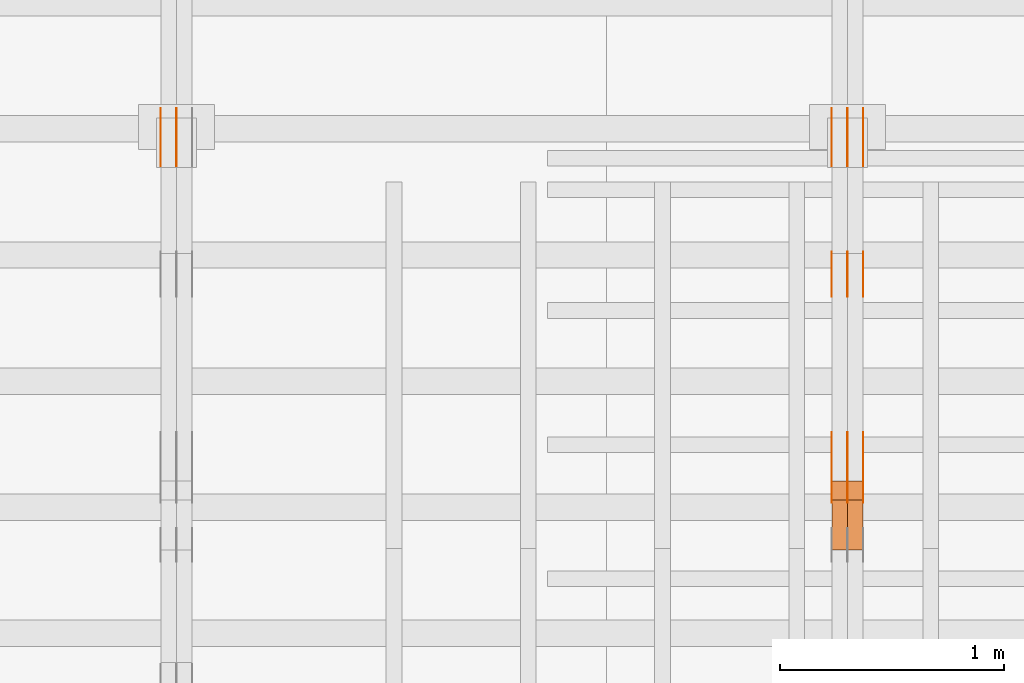
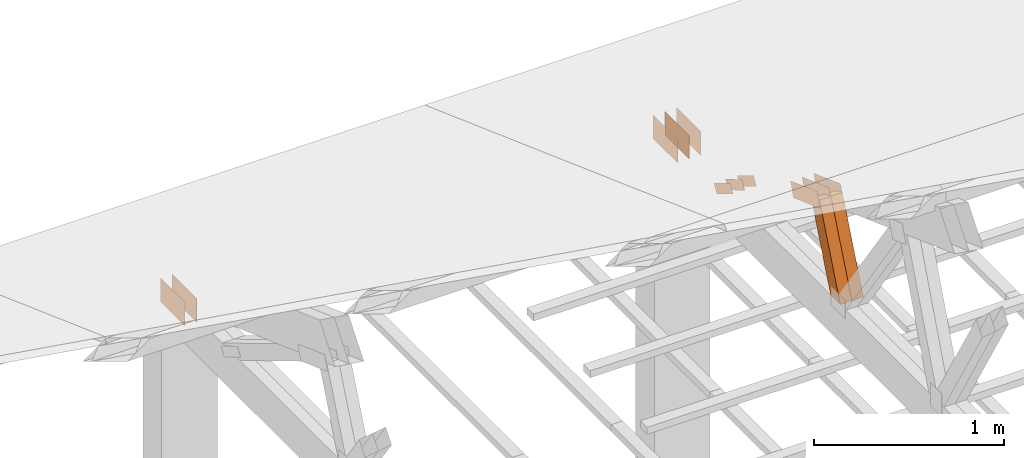
# One storey, part 172 of 189: 16 proxies.
"""IFC2X3 building model written with IfcOpenShell, lengths in millimetres."""

from ifc_helpers import new_model, entity, si_unit, converted_unit, derived_unit, direction, frame, origin, origin_2d_with_axis, place, context, subcontext, project, spatial, polyline, rectangle, outline, extrude, source, transform, mapped, material, type_object, type_shapes, element, save


model = new_model("IFC2X3")

# Units and contexts
model_context = context("Model", 3, precision=0.01, world=origin(), true_north=direction((6.12303176911189e-17, 1.0)))
body_context = subcontext(model_context, "Body", "Model", "MODEL_VIEW")
ifc_project = project(units=[si_unit("LENGTHUNIT", "METRE", prefix="MILLI"), si_unit("AREAUNIT", "SQUARE_METRE"), si_unit("VOLUMEUNIT", "CUBIC_METRE"), converted_unit("PLANEANGLEUNIT", "DEGREE", entity("IfcRatioMeasure", 0.0174532925199433), si_unit("PLANEANGLEUNIT", "RADIAN"), dimensions=[0, 0, 0, 0, 0, 0, 0]), si_unit("MASSUNIT", "GRAM", prefix="KILO"), derived_unit("MASSDENSITYUNIT", [(si_unit("MASSUNIT", "GRAM", prefix="KILO"), 1), (si_unit("LENGTHUNIT", "METRE"), -3)]), si_unit("TIMEUNIT", "SECOND"), si_unit("FREQUENCYUNIT", "HERTZ"), si_unit("THERMODYNAMICTEMPERATUREUNIT", "DEGREE_CELSIUS"), derived_unit("THERMALTRANSMITTANCEUNIT", [(si_unit("MASSUNIT", "GRAM", prefix="KILO"), 1), (si_unit("THERMODYNAMICTEMPERATUREUNIT", "KELVIN"), -1), (si_unit("TIMEUNIT", "SECOND"), -3)]), derived_unit("VOLUMETRICFLOWRATEUNIT", [(si_unit("LENGTHUNIT", "METRE"), 3), (si_unit("TIMEUNIT", "SECOND"), -1)]), si_unit("ELECTRICCURRENTUNIT", "AMPERE"), si_unit("ELECTRICVOLTAGEUNIT", "VOLT"), si_unit("POWERUNIT", "WATT"), si_unit("FORCEUNIT", "NEWTON"), si_unit("ILLUMINANCEUNIT", "LUX"), si_unit("LUMINOUSFLUXUNIT", "LUMEN"), si_unit("LUMINOUSINTENSITYUNIT", "CANDELA"), derived_unit("USERDEFINED", [(si_unit("MASSUNIT", "GRAM", prefix="KILO"), -1), (si_unit("LENGTHUNIT", "METRE"), -2), (si_unit("TIMEUNIT", "SECOND"), 3), (si_unit("LUMINOUSFLUXUNIT", "LUMEN"), 1)]), derived_unit("LINEARVELOCITYUNIT", [(si_unit("LENGTHUNIT", "METRE"), 1), (si_unit("TIMEUNIT", "SECOND"), -1)]), si_unit("PRESSUREUNIT", "PASCAL"), derived_unit("USERDEFINED", [(si_unit("LENGTHUNIT", "METRE"), -2), (si_unit("MASSUNIT", "GRAM", prefix="KILO"), 1), (si_unit("TIMEUNIT", "SECOND"), -2)])], contexts=[model_context])

# Site, building, storey
site_placement = place(None, origin())
site = spatial("IfcSite", under=ifc_project, at=site_placement, CompositionType="ELEMENT")
building_placement = place(site_placement, origin())
building = spatial("IfcBuilding", under=site, at=building_placement, CompositionType="ELEMENT")
storey_placement = place(building_placement, origin())
storey = spatial("IfcBuildingStorey", under=building, at=storey_placement, Name="Default", CompositionType="ELEMENT", Elevation=0.0)

# Proxies
ifc_material_1 = material(Name="IfcSurfaceStyle #245852")
building_element_proxy_type_1 = type_object("IfcBuildingElementProxyType", PredefinedType="NOTDEFINED", material=ifc_material_1)
shared_shape_1 = source(origin(), body_context, "Body", "SweptSolid", [
    extrude(outline(polyline([(-150.000004175486, -48.0000091256405), (150.000055794777, -48.0000091256405), (149.99999373786, 48.0000091256405), (-150.000045357151, 48.0000091256405), (-150.000004175486, -48.0000091256405)])), frame((150.000055794777, 48.0000091256405, 0.0), z_axis=(0.0, 0.0, 1.0), x_axis=(-1.0, 0.0, 0.0)), (0.0, 0.0, 1.0), 1.29999999999999),
])
type_shapes(building_element_proxy_type_1, [shared_shape_1])
proxy_1_placement = place(building_placement, frame((45301.3, 28002.7008500375, 633.16821439849), z_axis=(-1.0, 0.0, 0.0), x_axis=(0.0, -0.939692620785908, 0.342020143325669)))
element("IfcBuildingElementProxy", 1, at=proxy_1_placement, inside=storey, type_object=building_element_proxy_type_1, material=ifc_material_1, context=body_context, shape_type="MappedRepresentation", body=[
    mapped(shared_shape_1, transform((0.0, 0.0, 0.0), scale=1.0)),
])
ifc_material_2 = material(Name="IfcSurfaceStyle #245795")
building_element_proxy_type_2 = type_object("IfcBuildingElementProxyType", PredefinedType="NOTDEFINED", material=ifc_material_2)
shared_shape_2 = source(origin(), body_context, "Body", "SweptSolid", [
    extrude(outline(polyline([(-150.000004175486, -48.0000091256405), (150.000055794777, -48.0000091256405), (149.99999373786, 48.0000091256405), (-150.000045357151, 48.0000091256405), (-150.000004175486, -48.0000091256405)])), frame((150.000055794777, 48.0000091256405, 0.0), z_axis=(0.0, 0.0, 1.0), x_axis=(-1.0, 0.0, 0.0)), (0.0, 0.0, 1.0), 1.29999999999998),
])
type_shapes(building_element_proxy_type_2, [shared_shape_2])
proxy_2_placement = place(building_placement, frame((45230.0, 28002.7008500375, 633.16821439849), z_axis=(-1.0, 0.0, 0.0), x_axis=(0.0, -0.939692620785908, 0.342020143325669)))
element("IfcBuildingElementProxy", 2, at=proxy_2_placement, inside=storey, type_object=building_element_proxy_type_2, material=ifc_material_2, context=body_context, shape_type="MappedRepresentation", body=[
    mapped(shared_shape_2, transform((0.0, 0.0, 0.0), scale=1.0)),
])
ifc_material_3 = material(Name="IfcSurfaceStyle #245738")
building_element_proxy_type_3 = type_object("IfcBuildingElementProxyType", PredefinedType="NOTDEFINED", material=ifc_material_3)
shared_shape_3 = source(origin(), body_context, "Body", "SweptSolid", [
    extrude(outline(polyline([(-150.000004175486, -48.0000091256405), (150.000055794777, -48.0000091256405), (149.99999373786, 48.0000091256405), (-150.000045357151, 48.0000091256405), (-150.000004175486, -48.0000091256405)])), frame((150.000055794777, 48.0000091256405, 0.0), z_axis=(0.0, 0.0, 1.0), x_axis=(-1.0, 0.0, 0.0)), (0.0, 0.0, 1.0), 1.29999999999998),
])
type_shapes(building_element_proxy_type_3, [shared_shape_3])
proxy_3_placement = place(building_placement, frame((45231.3, 28002.7008500375, 633.16821439849), z_axis=(-1.0, 0.0, 0.0), x_axis=(0.0, -0.939692620785908, 0.342020143325669)))
element("IfcBuildingElementProxy", 3, at=proxy_3_placement, inside=storey, type_object=building_element_proxy_type_3, material=ifc_material_3, context=body_context, shape_type="MappedRepresentation", body=[
    mapped(shared_shape_3, transform((0.0, 0.0, 0.0), scale=1.0)),
])
ifc_material_4 = material(Name="IfcSurfaceStyle #245681")
building_element_proxy_type_4 = type_object("IfcBuildingElementProxyType", PredefinedType="NOTDEFINED", material=ifc_material_4)
shared_shape_4 = source(origin(), body_context, "Body", "SweptSolid", [
    extrude(outline(polyline([(-150.000004175486, -48.0000091256405), (150.000055794777, -48.0000091256405), (149.99999373786, 48.0000091256405), (-150.000045357151, 48.0000091256405), (-150.000004175486, -48.0000091256405)])), frame((150.000055794777, 48.0000091256405, 0.0), z_axis=(0.0, 0.0, 1.0), x_axis=(-1.0, 0.0, 0.0)), (0.0, 0.0, 1.0), 1.29999999999998),
])
type_shapes(building_element_proxy_type_4, [shared_shape_4])
proxy_4_placement = place(building_placement, frame((45160.0, 28002.7008500375, 633.16821439849), z_axis=(-1.0, 0.0, 0.0), x_axis=(0.0, -0.939692620785908, 0.342020143325669)))
element("IfcBuildingElementProxy", 4, at=proxy_4_placement, inside=storey, type_object=building_element_proxy_type_4, material=ifc_material_4, context=body_context, shape_type="MappedRepresentation", body=[
    mapped(shared_shape_4, transform((0.0, 0.0, 0.0), scale=1.0)),
])
ifc_material_5 = material(Name="IfcSurfaceStyle #245624")
building_element_proxy_type_5 = type_object("IfcBuildingElementProxyType", PredefinedType="NOTDEFINED", material=ifc_material_5)
shared_shape_5 = source(origin(), body_context, "Body", "SweptSolid", [
    extrude(outline(polyline([(-100.000014621824, -30.0000173081658), (100.000025679578, -30.0000173081658), (100.000010707989, 30.0000173081658), (-100.000021765743, 30.0000173081658), (-100.000014621824, -30.0000173081658)])), frame((100.000025679578, 30.0000173081658, 0.0), z_axis=(0.0, 0.0, 1.0), x_axis=(-1.0, 0.0, 0.0)), (0.0, 0.0, 1.0), 1.3),
])
type_shapes(building_element_proxy_type_5, [shared_shape_5])
proxy_5_placement = place(building_placement, frame((45301.3, 28812.2744732883, 167.948789809131), z_axis=(-1.0, 0.0, 0.0), x_axis=(0.0, -0.858392121304013, 0.51299411895576)))
element("IfcBuildingElementProxy", 5, at=proxy_5_placement, inside=storey, type_object=building_element_proxy_type_5, material=ifc_material_5, context=body_context, shape_type="MappedRepresentation", body=[
    mapped(shared_shape_5, transform((0.0, 0.0, 0.0), scale=1.0)),
])
ifc_material_6 = material(Name="IfcSurfaceStyle #245567")
building_element_proxy_type_6 = type_object("IfcBuildingElementProxyType", PredefinedType="NOTDEFINED", material=ifc_material_6)
shared_shape_6 = source(origin(), body_context, "Body", "SweptSolid", [
    extrude(outline(polyline([(-100.000014621824, -30.0000173081658), (100.000025679578, -30.0000173081658), (100.000010707989, 30.0000173081658), (-100.000021765743, 30.0000173081658), (-100.000014621824, -30.0000173081658)])), frame((100.000025679578, 30.0000173081658, 0.0), z_axis=(0.0, 0.0, 1.0), x_axis=(-1.0, 0.0, 0.0)), (0.0, 0.0, 1.0), 1.29999999999998),
])
type_shapes(building_element_proxy_type_6, [shared_shape_6])
proxy_6_placement = place(building_placement, frame((45230.0, 28812.2744732883, 167.948789809131), z_axis=(-1.0, 0.0, 0.0), x_axis=(0.0, -0.858392121304013, 0.51299411895576)))
element("IfcBuildingElementProxy", 6, at=proxy_6_placement, inside=storey, type_object=building_element_proxy_type_6, material=ifc_material_6, context=body_context, shape_type="MappedRepresentation", body=[
    mapped(shared_shape_6, transform((0.0, 0.0, 0.0), scale=1.0)),
])
ifc_material_7 = material(Name="IfcSurfaceStyle #245510")
building_element_proxy_type_7 = type_object("IfcBuildingElementProxyType", PredefinedType="NOTDEFINED", material=ifc_material_7)
shared_shape_7 = source(origin(), body_context, "Body", "SweptSolid", [
    extrude(outline(polyline([(-100.000014621824, -30.0000173081658), (100.000025679578, -30.0000173081658), (100.000010707989, 30.0000173081658), (-100.000021765743, 30.0000173081658), (-100.000014621824, -30.0000173081658)])), frame((100.000025679578, 30.0000173081658, 0.0), z_axis=(0.0, 0.0, 1.0), x_axis=(-1.0, 0.0, 0.0)), (0.0, 0.0, 1.0), 1.29999999999998),
])
type_shapes(building_element_proxy_type_7, [shared_shape_7])
proxy_7_placement = place(building_placement, frame((45231.3, 28812.2744732883, 167.948789809131), z_axis=(-1.0, 0.0, 0.0), x_axis=(0.0, -0.858392121304013, 0.51299411895576)))
element("IfcBuildingElementProxy", 7, at=proxy_7_placement, inside=storey, type_object=building_element_proxy_type_7, material=ifc_material_7, context=body_context, shape_type="MappedRepresentation", body=[
    mapped(shared_shape_7, transform((0.0, 0.0, 0.0), scale=1.0)),
])
ifc_material_8 = material(Name="IfcSurfaceStyle #245453")
building_element_proxy_type_8 = type_object("IfcBuildingElementProxyType", PredefinedType="NOTDEFINED", material=ifc_material_8)
shared_shape_8 = source(origin(), body_context, "Body", "SweptSolid", [
    extrude(outline(polyline([(-100.000014621824, -30.0000173081658), (100.000025679578, -30.0000173081658), (100.000010707989, 30.0000173081658), (-100.000021765743, 30.0000173081658), (-100.000014621824, -30.0000173081658)])), frame((100.000025679578, 30.0000173081658, 0.0), z_axis=(0.0, 0.0, 1.0), x_axis=(-1.0, 0.0, 0.0)), (0.0, 0.0, 1.0), 1.29999999999999),
])
type_shapes(building_element_proxy_type_8, [shared_shape_8])
proxy_8_placement = place(building_placement, frame((45160.0, 28812.2744732883, 167.948789809131), z_axis=(-1.0, 0.0, 0.0), x_axis=(0.0, -0.858392121304013, 0.51299411895576)))
element("IfcBuildingElementProxy", 8, at=proxy_8_placement, inside=storey, type_object=building_element_proxy_type_8, material=ifc_material_8, context=body_context, shape_type="MappedRepresentation", body=[
    mapped(shared_shape_8, transform((0.0, 0.0, 0.0), scale=1.0)),
])
ifc_material_9 = material(Name="IfcSurfaceStyle #245168")
building_element_proxy_type_9 = type_object("IfcBuildingElementProxyType", PredefinedType="NOTDEFINED", material=ifc_material_9)
shared_shape_9 = source(origin(), body_context, "Body", "SweptSolid", [
    extrude(rectangle(XDim=258.000001907349, YDim=151.999992370605, at=origin_2d_with_axis()), frame((129.000001782157, 75.9999961853027, 0.0), z_axis=(0.0, 0.0, 1.0), x_axis=(-1.0, 0.0, 0.0)), (0.0, 0.0, 1.0), 0.999999999999984),
])
type_shapes(building_element_proxy_type_9, [shared_shape_9])
proxy_9_placement = place(building_placement, frame((45301.0, 29483.7634609878, 116.138221740723), z_axis=(-1.0, 0.0, 0.0), x_axis=(0.0, -1.0, 0.0)))
element("IfcBuildingElementProxy", 9, at=proxy_9_placement, inside=storey, type_object=building_element_proxy_type_9, material=ifc_material_9, Name="GNT100S 152x258", context=body_context, shape_type="MappedRepresentation", body=[
    mapped(shared_shape_9, transform((0.0, 0.0, 0.0), scale=1.0)),
])
ifc_material_10 = material(Name="IfcSurfaceStyle #245111")
building_element_proxy_type_10 = type_object("IfcBuildingElementProxyType", PredefinedType="NOTDEFINED", material=ifc_material_10)
shared_shape_10 = source(origin(), body_context, "Body", "SweptSolid", [
    extrude(rectangle(XDim=258.000001907349, YDim=151.999992370605, at=origin_2d_with_axis()), frame((129.000001782157, 75.9999961853027, 0.0), z_axis=(0.0, 0.0, 1.0), x_axis=(-1.0, 0.0, 0.0)), (0.0, 0.0, 1.0), 0.999999999999984),
])
type_shapes(building_element_proxy_type_10, [shared_shape_10])
proxy_10_placement = place(building_placement, frame((45230.0, 29483.7634609878, 116.138221740723), z_axis=(-1.0, 0.0, 0.0), x_axis=(0.0, -1.0, 0.0)))
element("IfcBuildingElementProxy", 10, at=proxy_10_placement, inside=storey, type_object=building_element_proxy_type_10, material=ifc_material_10, Name="GNT100S 152x258", context=body_context, shape_type="MappedRepresentation", body=[
    mapped(shared_shape_10, transform((0.0, 0.0, 0.0), scale=1.0)),
])
ifc_material_11 = material(Name="IfcSurfaceStyle #245054")
building_element_proxy_type_11 = type_object("IfcBuildingElementProxyType", PredefinedType="NOTDEFINED", material=ifc_material_11)
shared_shape_11 = source(origin(), body_context, "Body", "SweptSolid", [
    extrude(rectangle(XDim=258.000001907349, YDim=151.999992370605, at=origin_2d_with_axis()), frame((129.000001782157, 75.9999961853027, 0.0), z_axis=(0.0, 0.0, 1.0), x_axis=(-1.0, 0.0, 0.0)), (0.0, 0.0, 1.0), 0.999999999999984),
])
type_shapes(building_element_proxy_type_11, [shared_shape_11])
proxy_11_placement = place(building_placement, frame((45231.0, 29483.7634609878, 116.138221740723), z_axis=(-1.0, 0.0, 0.0), x_axis=(0.0, -1.0, 0.0)))
element("IfcBuildingElementProxy", 11, at=proxy_11_placement, inside=storey, type_object=building_element_proxy_type_11, material=ifc_material_11, Name="GNT100S 152x258", context=body_context, shape_type="MappedRepresentation", body=[
    mapped(shared_shape_11, transform((0.0, 0.0, 0.0), scale=1.0)),
])
ifc_material_12 = material(Name="IfcSurfaceStyle #244997")
building_element_proxy_type_12 = type_object("IfcBuildingElementProxyType", PredefinedType="NOTDEFINED", material=ifc_material_12)
shared_shape_12 = source(origin(), body_context, "Body", "SweptSolid", [
    extrude(rectangle(XDim=258.000001907349, YDim=151.999992370605, at=origin_2d_with_axis()), frame((129.000001782157, 75.9999961853027, 0.0), z_axis=(0.0, 0.0, 1.0), x_axis=(-1.0, 0.0, 0.0)), (0.0, 0.0, 1.0), 0.999999999999984),
])
type_shapes(building_element_proxy_type_12, [shared_shape_12])
proxy_12_placement = place(building_placement, frame((45160.0, 29483.7634609878, 116.138221740723), z_axis=(-1.0, 0.0, 0.0), x_axis=(0.0, -1.0, 0.0)))
element("IfcBuildingElementProxy", 12, at=proxy_12_placement, inside=storey, type_object=building_element_proxy_type_12, material=ifc_material_12, Name="GNT100S 152x258", context=body_context, shape_type="MappedRepresentation", body=[
    mapped(shared_shape_12, transform((0.0, 0.0, 0.0), scale=1.0)),
])
ifc_material_13 = material(Name="IfcSurfaceStyle #238760")
building_element_proxy_type_13 = type_object("IfcBuildingElementProxyType", Name="T1-W15 238758", PredefinedType="NOTDEFINED", material=ifc_material_13)
shared_shape_13 = source(origin(), body_context, "Body", "SweptSolid", [
    extrude(outline(polyline([(-356.314733086722, -47.5000181042257), (225.500284389883, -47.5000181042257), (227.502094104438, -2.00397075419828e-05), (220.445344962296, 47.5000281240794), (-317.132990369895, 47.5000281240795), (-356.314733086722, -47.5000181042257)])), frame((227.502118521083, 47.5000281240794, 0.0), z_axis=(0.0, 0.0, 1.0), x_axis=(-1.0, 0.0, 0.0)), (0.0, 0.0, 1.0), 70.0),
])
type_shapes(building_element_proxy_type_13, [shared_shape_13])
proxy_13_placement = place(building_placement, frame((45300.0, 27820.3452927615, 748.492381554869), z_axis=(-1.0, 0.0, 0.0), x_axis=(0.0, -0.38128326679549, -0.9244582578255)))
element("IfcBuildingElementProxy", 13, at=proxy_13_placement, inside=storey, type_object=building_element_proxy_type_13, material=ifc_material_13, Name="T1-W15", context=body_context, shape_type="MappedRepresentation", body=[
    mapped(shared_shape_13, transform((0.0, 0.0, 0.0), scale=1.0)),
])
ifc_material_14 = material(Name="IfcSurfaceStyle #238694")
building_element_proxy_type_14 = type_object("IfcBuildingElementProxyType", Name="T1-W15 238692", PredefinedType="NOTDEFINED", material=ifc_material_14)
shared_shape_14 = source(origin(), body_context, "Body", "SweptSolid", [
    extrude(outline(polyline([(-356.314733086722, -47.5000181042257), (225.500284389883, -47.5000181042257), (227.502094104438, -2.00397075419828e-05), (220.445344962296, 47.5000281240794), (-317.132990369895, 47.5000281240795), (-356.314733086722, -47.5000181042257)])), frame((227.502118521083, 47.5000281240794, 0.0), z_axis=(0.0, 0.0, 1.0), x_axis=(-1.0, 0.0, 0.0)), (0.0, 0.0, 1.0), 70.0),
])
type_shapes(building_element_proxy_type_14, [shared_shape_14])
proxy_14_placement = place(building_placement, frame((45230.0, 27820.3452927615, 748.492381554869), z_axis=(-1.0, 0.0, 0.0), x_axis=(0.0, -0.38128326679549, -0.9244582578255)))
element("IfcBuildingElementProxy", 14, at=proxy_14_placement, inside=storey, type_object=building_element_proxy_type_14, material=ifc_material_14, Name="T1-W15", context=body_context, shape_type="MappedRepresentation", body=[
    mapped(shared_shape_14, transform((0.0, 0.0, 0.0), scale=1.0)),
])
ifc_material_15 = material(Name="IfcSurfaceStyle #229264")
building_element_proxy_type_15 = type_object("IfcBuildingElementProxyType", PredefinedType="NOTDEFINED", material=ifc_material_15)
shared_shape_15 = source(origin(), body_context, "Body", "SweptSolid", [
    extrude(rectangle(XDim=258.000001907349, YDim=151.999992370605, at=origin_2d_with_axis()), frame((129.000001782157, 75.9999961853027, 0.0), z_axis=(0.0, 0.0, 1.0), x_axis=(-1.0, 0.0, 0.0)), (0.0, 0.0, 1.0), 0.999999999999984),
])
type_shapes(building_element_proxy_type_15, [shared_shape_15])
proxy_15_placement = place(building_placement, frame((42231.0, 29483.7634609878, 116.138221740723), z_axis=(-1.0, 0.0, 0.0), x_axis=(0.0, -1.0, 0.0)))
element("IfcBuildingElementProxy", 15, at=proxy_15_placement, inside=storey, type_object=building_element_proxy_type_15, material=ifc_material_15, Name="GNT100S 152x258", context=body_context, shape_type="MappedRepresentation", body=[
    mapped(shared_shape_15, transform((0.0, 0.0, 0.0), scale=1.0)),
])
ifc_material_16 = material(Name="IfcSurfaceStyle #229207")
building_element_proxy_type_16 = type_object("IfcBuildingElementProxyType", PredefinedType="NOTDEFINED", material=ifc_material_16)
shared_shape_16 = source(origin(), body_context, "Body", "SweptSolid", [
    extrude(rectangle(XDim=258.000001907349, YDim=151.999992370605, at=origin_2d_with_axis()), frame((129.000001782157, 75.9999961853027, 0.0), z_axis=(0.0, 0.0, 1.0), x_axis=(-1.0, 0.0, 0.0)), (0.0, 0.0, 1.0), 0.999999999999984),
])
type_shapes(building_element_proxy_type_16, [shared_shape_16])
proxy_16_placement = place(building_placement, frame((42160.0, 29483.7634609878, 116.138221740723), z_axis=(-1.0, 0.0, 0.0), x_axis=(0.0, -1.0, 0.0)))
element("IfcBuildingElementProxy", 16, at=proxy_16_placement, inside=storey, type_object=building_element_proxy_type_16, material=ifc_material_16, Name="GNT100S 152x258", context=body_context, shape_type="MappedRepresentation", body=[
    mapped(shared_shape_16, transform((0.0, 0.0, 0.0), scale=1.0)),
])

save(model, "model.ifc")
